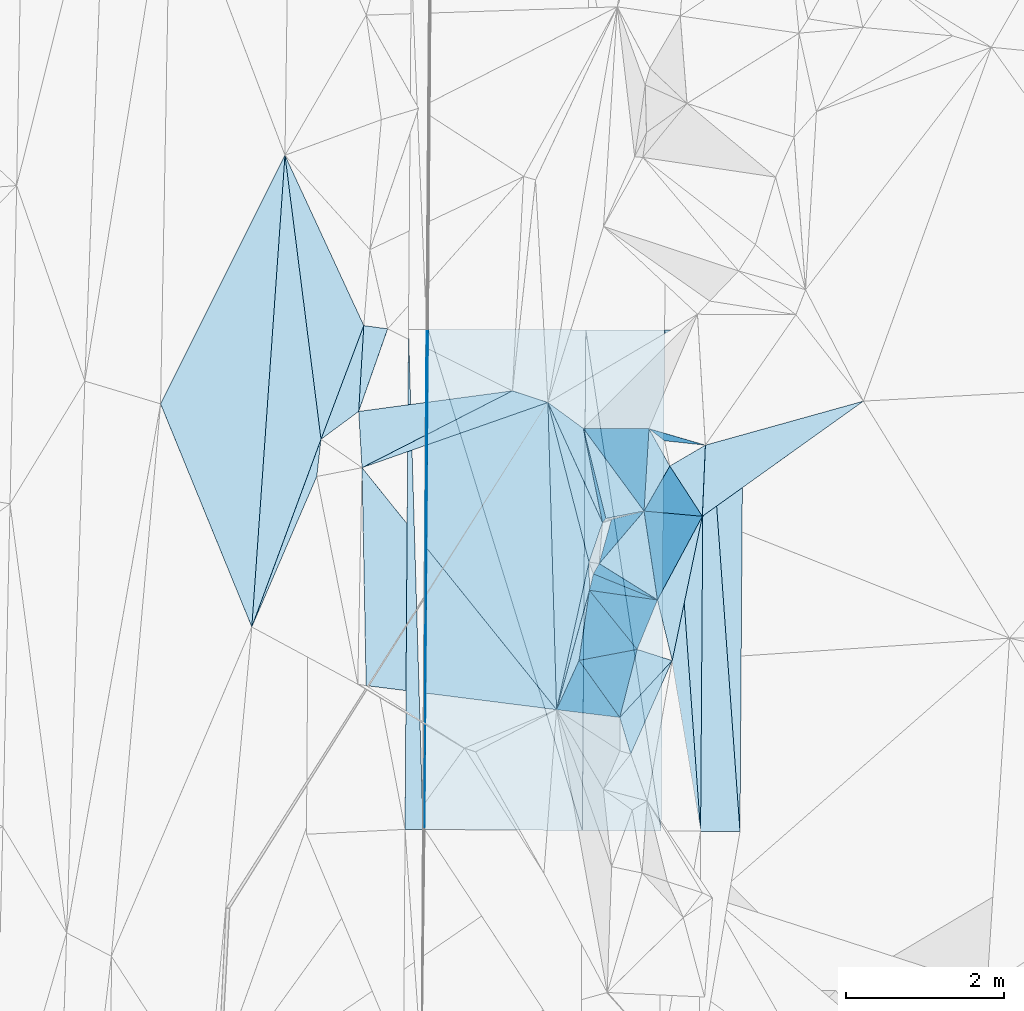
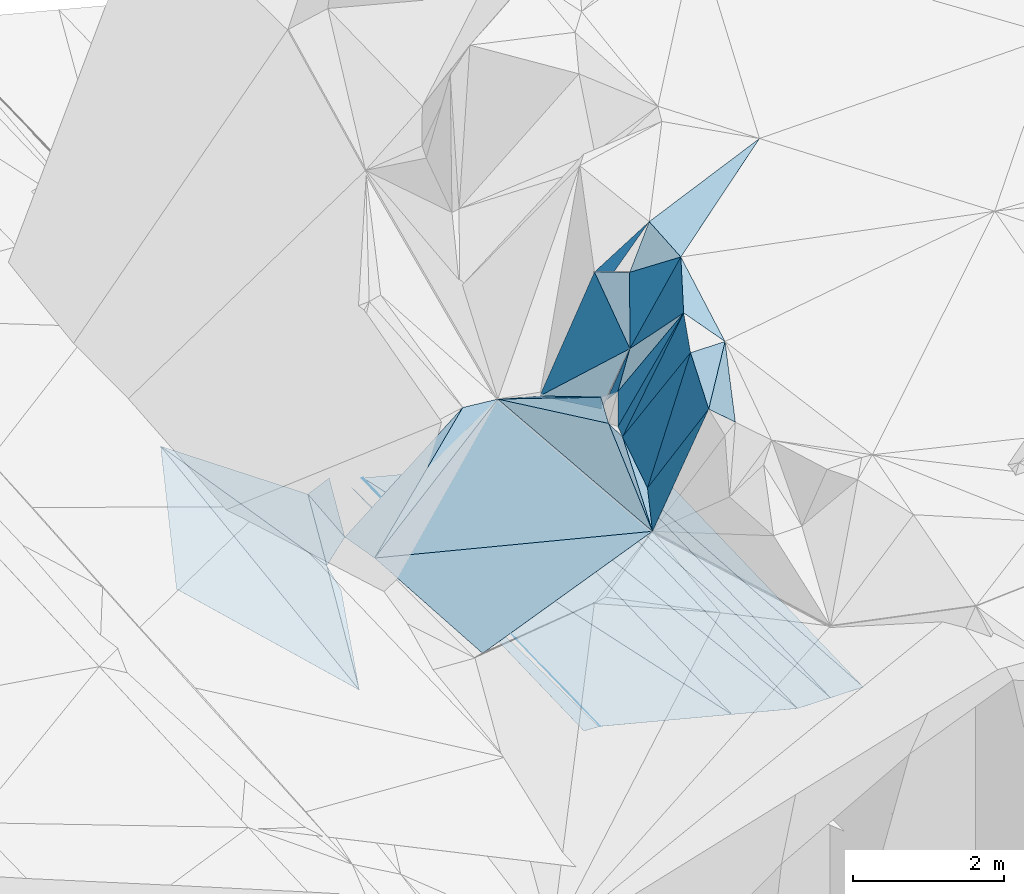
# One storey, part 151 of 275: 45 plates.
"""IFC2X3 building model written with IfcOpenShell, lengths in millimetres."""

from ifc_helpers import new_model, si_unit, frame, origin_with_axes, place, context, subcontext, project, spatial, polyline, outline, extrude, material, type_object, element, save


model = new_model("IFC2X3")

# Units and contexts
model_context = context("Model", 3, precision=1e-05, world=origin_with_axes())
body_context = subcontext(model_context, "Body", "Model", "MODEL_VIEW")
ifc_project = project(units=[si_unit("LENGTHUNIT", "METRE", prefix="MILLI"), si_unit("AREAUNIT", "SQUARE_METRE"), si_unit("VOLUMEUNIT", "CUBIC_METRE"), si_unit("MASSUNIT", "GRAM", prefix="KILO"), si_unit("TIMEUNIT", "SECOND"), si_unit("PLANEANGLEUNIT", "RADIAN"), si_unit("SOLIDANGLEUNIT", "STERADIAN"), si_unit("THERMODYNAMICTEMPERATUREUNIT", "DEGREE_CELSIUS"), si_unit("LUMINOUSINTENSITYUNIT", "LUMEN")], contexts=[model_context])

# Site, building, storey
site_placement = place(None, origin_with_axes())
site = spatial("IfcSite", under=ifc_project, at=site_placement, CompositionType="ELEMENT")
building_placement = place(site_placement, origin_with_axes())
building = spatial("IfcBuilding", under=site, at=building_placement, Name="Undefined", CompositionType="ELEMENT")
storey_placement = place(building_placement, origin_with_axes())
storey = spatial("IfcBuildingStorey", under=building, at=storey_placement, Name="Undefined", CompositionType="ELEMENT", Elevation=0.0)

# Plates
ifc_material = material()
plate_type_1 = type_object("IfcPlateType", PredefinedType="NOTDEFINED")
plate_1_placement = place(storey_placement, frame((-56001.0922795183, 121927.905972609, 43287.7527590777), z_axis=(-0.0497168788209874, 0.0234397140197796, -0.998488263209423), x_axis=(0.00374288792598746, 0.999721923798681, 0.0232823080092753)))
element("IfcPlate", 1, at=plate_1_placement, inside=storey, type_object=plate_type_1, material=ifc_material, Name="00_PR", context=body_context, shape_type="SweptSolid", body=[
    extrude(outline(polyline([(0.0, 0.0), (6347.1796875, 1.09139364212751e-09), (6347.1806640625, 20.0242137908936), (0.0, 0.0)])), frame((-8.85201319254618e-08, 2.18876761149539e-07, -0.5000001331573), z_axis=(0.0, 0.0, 1.0), x_axis=(1.0, 0.0, 0.0)), (0.0, 0.0, 1.0), 1.0),
])
plate_type_2 = type_object("IfcPlateType", PredefinedType="NOTDEFINED")
plate_2_placement = place(storey_placement, frame((-54328.6092559601, 123448.215957346, 44928.528851486), z_axis=(0.255303228601338, 0.21652061744537, -0.942305196678236), x_axis=(0.25502810990825, 0.925007291391266, 0.28164192519868)))
element("IfcPlate", 2, at=plate_2_placement, inside=storey, type_object=plate_type_2, material=ifc_material, Name="00", context=body_context, shape_type="SweptSolid", body=[
    extrude(outline(polyline([(0.0, 0.0), (1636.83020019531, -5.96628524363041e-10), (713.142395019531, 111.359382629395), (0.0, 0.0)])), frame((-8.85201319254618e-08, 2.18876761149539e-07, -0.5000001331573), z_axis=(0.0, 0.0, 1.0), x_axis=(1.0, 0.0, 0.0)), (0.0, 0.0, 1.0), 1.0),
])
plate_type_3 = type_object("IfcPlateType", PredefinedType="NOTDEFINED")
plate_3_placement = place(storey_placement, frame((-52501.1382562294, 121905.627300708, 42537.7521357024), z_axis=(0.000147264085346254, 0.0231375696408005, -0.999732279755138), x_axis=(0.00689524187971411, 0.999708501001947, 0.0231380350043184)))
element("IfcPlate", 3, at=plate_3_placement, inside=storey, type_object=plate_type_3, material=ifc_material, Name="00_PR", context=body_context, shape_type="SweptSolid", body=[
    extrude(outline(polyline([(0.0, 0.0), (6360.56591796875, -3.68527253158391e-08), (0.266177088022232, 499.999298095703), (0.0, 0.0)])), frame((-8.85201319254618e-08, 2.18876761149539e-07, -0.5000001331573), z_axis=(0.0, 0.0, 1.0), x_axis=(1.0, 0.0, 0.0)), (0.0, 0.0, 1.0), 1.0),
])
plate_4_placement = place(storey_placement, frame((-53001.1288192393, 121908.81010767, 42537.7521355578), z_axis=(0.000147275333863045, 0.0231357015361885, -0.999732322986711), x_axis=(0.00689520387458397, 0.999708544496369, 0.0231361670221856)))
element("IfcPlate", 4, at=plate_4_placement, inside=storey, type_object=plate_type_3, material=ifc_material, Name="00_PR", context=body_context, shape_type="SweptSolid", body=[
    extrude(outline(polyline([(0.0, 0.0), (6358.6591796875, -4.38012648373842e-08), (0.26565757393837, 500.000610351563), (0.0, 0.0)])), frame((-8.85201319254618e-08, 2.18876761149539e-07, -0.5000001331573), z_axis=(0.0, 0.0, 1.0), x_axis=(1.0, 0.0, 0.0)), (0.0, 0.0, 1.0), 1.0),
])
plate_type_4 = type_object("IfcPlateType", PredefinedType="NOTDEFINED")
plate_5_placement = place(storey_placement, frame((-56251.0873551612, 121929.496915818, 43300.2527590753), z_axis=(-0.0497761688804347, 0.0234391149956503, -0.998485323327192), x_axis=(0.00689365892853949, 0.99970883258603, 0.0231241760080976)))
element("IfcPlate", 5, at=plate_5_placement, inside=storey, type_object=plate_type_4, material=ifc_material, Name="00_PR", context=body_context, shape_type="SweptSolid", body=[
    extrude(outline(polyline([(0.0, 0.0), (6346.2587890625, 5.02768671140075e-09), (-0.144051283597946, 230.286834716797), (0.0, 0.0)])), frame((-8.85201319254618e-08, 2.18876761149539e-07, -0.5000001331573), z_axis=(0.0, 0.0, 1.0), x_axis=(1.0, 0.0, 0.0)), (0.0, 0.0, 1.0), 1.0),
])
plate_type_5 = type_object("IfcPlateType", PredefinedType="NOTDEFINED")
plate_6_placement = place(storey_placement, frame((-51957.2761406581, 128263.064040456, 42684.9791359133), z_axis=(0.00017098723566966, 0.0231392690260512, -0.999732236647546), x_axis=(-0.00689556590937803, -0.999708455647234, -0.0231398979732495)))
element("IfcPlate", 6, at=plate_6_placement, inside=storey, type_object=plate_type_5, material=ifc_material, Name="00_PR", context=body_context, shape_type="SweptSolid", body=[
    extrude(outline(polyline([(0.0, 0.0), (6362.47412109375, 1.97615008801222e-08), (2.17418122291565, 500.001373291016), (0.0, 0.0)])), frame((-8.85201319254618e-08, 2.18876761149539e-07, -0.5000001331573), z_axis=(0.0, 0.0, 1.0), x_axis=(1.0, 0.0, 0.0)), (0.0, 0.0, 1.0), 1.0),
])
plate_7_placement = place(storey_placement, frame((-52457.2806044433, 128264.339338575, 42684.9231357941), z_axis=(0.000171043884283166, 0.0231374056254346, -0.999732279765395), x_axis=(-0.00689524188068983, -0.999708501001948, -0.0231380350039911)))
element("IfcPlate", 7, at=plate_7_placement, inside=storey, type_object=plate_type_5, material=ifc_material, Name="00_PR", context=body_context, shape_type="SweptSolid", body=[
    extrude(outline(polyline([(0.0, 0.0), (6360.56591796875, -3.68527253158391e-08), (2.172696352005, 500.000854492188), (0.0, 0.0)])), frame((-8.85201319254618e-08, 2.18876761149539e-07, -0.5000001331573), z_axis=(0.0, 0.0, 1.0), x_axis=(1.0, 0.0, 0.0)), (0.0, 0.0, 1.0), 1.0),
])
plate_type_6 = type_object("IfcPlateType", PredefinedType="NOTDEFINED")
plate_8_placement = place(storey_placement, frame((-52957.4057922976, 128265.61644964, 42684.8820515383), z_axis=(-0.242302793099637, 0.024117544904854, -0.969900871472893), x_axis=(-0.00689520387730406, -0.999708544496402, -0.0231361670199542)))
element("IfcPlate", 8, at=plate_8_placement, inside=storey, type_object=plate_type_6, material=ifc_material, Name="00_PR", context=body_context, shape_type="SweptSolid", body=[
    extrude(outline(polyline([(0.0, 0.0), (6358.6591796875, -4.38012648373842e-08), (-1.43695330619812, 1030.76049804688), (0.0, 0.0)])), frame((-8.85201319254618e-08, 2.18876761149539e-07, -0.5000001331573), z_axis=(0.0, 0.0, 1.0), x_axis=(1.0, 0.0, 0.0)), (0.0, 0.0, 1.0), 1.0),
])
plate_9_placement = place(storey_placement, frame((-54001.2298594987, 121915.175695106, 42787.7670540484), z_axis=(-0.242325245624138, 0.0241138246358994, -0.969895354558743), x_axis=(0.00689469788792795, 0.999708634394564, 0.0231324330322171)))
element("IfcPlate", 9, at=plate_9_placement, inside=storey, type_object=plate_type_6, material=ifc_material, Name="00_PR", context=body_context, shape_type="SweptSolid", body=[
    extrude(outline(polyline([(0.0, 0.0), (6354.84375, 3.70855559594929e-08), (-5.25179862976074, 1030.76306152344), (0.0, 0.0)])), frame((-8.85201319254618e-08, 2.18876761149539e-07, -0.5000001331573), z_axis=(0.0, 0.0, 1.0), x_axis=(1.0, 0.0, 0.0)), (0.0, 0.0, 1.0), 1.0),
])
plate_type_7 = type_object("IfcPlateType", PredefinedType="NOTDEFINED")
plate_10_placement = place(storey_placement, frame((-55957.4324484603, 128273.270476872, 43434.5470512358), z_axis=(-0.242303436498094, 0.0241138005015226, -0.96990080383851), x_axis=(0.970165469879808, -0.00247512188093162, -0.242431092940995)))
element("IfcPlate", 10, at=plate_10_placement, inside=storey, type_object=plate_type_7, material=ifc_material, Name="00_PR", context=body_context, shape_type="SweptSolid", body=[
    extrude(outline(polyline([(0.0, 0.0), (2061.52197265625, 4.61295712739229e-09), (2070.376953125, 6354.837890625), (0.0, 0.0)])), frame((-8.85201319254618e-08, 2.18876761149539e-07, -0.5000001331573), z_axis=(0.0, 0.0, 1.0), x_axis=(1.0, 0.0, 0.0)), (0.0, 0.0, 1.0), 1.0),
])
plate_type_8 = type_object("IfcPlateType", PredefinedType="NOTDEFINED")
plate_11_placement = place(storey_placement, frame((-55957.4324484603, 128273.270476872, 43434.5470512358), z_axis=(-0.242325431720713, 0.0241064926841434, -0.969895490324519), x_axis=(0.292687249134254, -0.951298844031144, -0.0967712950168195)))
element("IfcPlate", 11, at=plate_11_placement, inside=storey, type_object=plate_type_8, material=ifc_material, Name="00_PR", context=body_context, shape_type="SweptSolid", body=[
    extrude(outline(polyline([(0.0, 0.0), (6683.59375, 3.28655005432665e-08), (6037.73486328125, 1957.77001953125), (0.0, 0.0)])), frame((-8.85201319254618e-08, 2.18876761149539e-07, -0.5000001331573), z_axis=(0.0, 0.0, 1.0), x_axis=(1.0, 0.0, 0.0)), (0.0, 0.0, 1.0), 1.0),
])
plate_type_9 = type_object("IfcPlateType", PredefinedType="NOTDEFINED")
plate_12_placement = place(storey_placement, frame((-53387.166340567, 122886.851759459, 46699.5569787593), z_axis=(0.453175417801132, 0.0979237538987491, -0.886026511523863), x_axis=(-0.287532499343744, 0.956879604337603, -0.0413096190233257)))
element("IfcPlate", 12, at=plate_12_placement, inside=storey, type_object=plate_type_9, material=ifc_material, Name="00", context=body_context, shape_type="SweptSolid", body=[
    extrude(outline(polyline([(0.0, 0.0), (484.148742675781, -1.54250301420689e-09), (964.99267578125, 952.517211914063), (0.0, 0.0)])), frame((-8.85201319254618e-08, 2.18876761149539e-07, -0.5000001331573), z_axis=(0.0, 0.0, 1.0), x_axis=(1.0, 0.0, 0.0)), (0.0, 0.0, 1.0), 1.0),
])
plate_type_10 = type_object("IfcPlateType", PredefinedType="NOTDEFINED")
plate_13_placement = place(storey_placement, frame((-57316.9926377495, 126878.743560531, 43339.5068959017), z_axis=(0.165709531410516, -0.000848531309702812, -0.986174239774252), x_axis=(0.351640904343267, 0.934318861990843, 0.058283261068556)))
element("IfcPlate", 13, at=plate_13_placement, inside=storey, type_object=plate_type_10, material=ifc_material, Name="00", context=body_context, shape_type="SweptSolid", body=[
    extrude(outline(polyline([(0.0, 0.0), (1544.1826171875, -2.35741026699543e-09), (502.919799804688, 326.759368896484), (0.0, 0.0)])), frame((-8.85201319254618e-08, 2.18876761149539e-07, -0.5000001331573), z_axis=(0.0, 0.0, 1.0), x_axis=(1.0, 0.0, 0.0)), (0.0, 0.0, 1.0), 1.0),
])
plate_type_11 = type_object("IfcPlateType", PredefinedType="NOTDEFINED")
plate_14_placement = place(storey_placement, frame((-57774.4066346961, 130482.623841324, 43243.5081506116), z_axis=(-0.175732205588709, 0.0386520921781757, -0.983678914935752), x_axis=(-0.0701137544389572, -0.99718276376502, -0.0266570269990824)))
element("IfcPlate", 14, at=plate_14_placement, inside=storey, type_object=plate_type_11, material=ifc_material, Name="00", context=body_context, shape_type="SweptSolid", body=[
    extrude(outline(polyline([(0.0, 0.0), (6002.169921875, -5.25324139744043e-09), (3252.09106445313, 1375.0771484375), (0.0, 0.0)])), frame((-8.85201319254618e-08, 2.18876761149539e-07, -0.5000001331573), z_axis=(0.0, 0.0, 1.0), x_axis=(1.0, 0.0, 0.0)), (0.0, 0.0, 1.0), 1.0),
])
plate_type_12 = type_object("IfcPlateType", PredefinedType="NOTDEFINED")
plate_15_placement = place(storey_placement, frame((-53048.5054921934, 124840.718056682, 47159.5014563602), z_axis=(-0.0273068669384299, 0.0710520201318311, -0.997098764141844), x_axis=(0.472476560067046, 0.879937191340254, 0.0497638371052258)))
element("IfcPlate", 15, at=plate_15_placement, inside=storey, type_object=plate_type_12, material=ifc_material, Name="00", context=body_context, shape_type="SweptSolid", body=[
    extrude(outline(polyline([(0.0, 0.0), (1205.69482421875, -2.6338966563344e-09), (-592.023803710938, 530.196044921875), (0.0, 0.0)])), frame((-8.85201319254618e-08, 2.18876761149539e-07, -0.5000001331573), z_axis=(0.0, 0.0, 1.0), x_axis=(1.0, 0.0, 0.0)), (0.0, 0.0, 1.0), 1.0),
])
plate_type_13 = type_object("IfcPlateType", PredefinedType="NOTDEFINED")
plate_16_placement = place(storey_placement, frame((-53048.1583882639, 124840.43578799, 47159.7208484749), z_axis=(0.666902251379512, -0.493484165114308, -0.558314217879478), x_axis=(-0.474975247137563, 0.295790272119445, -0.828798304490372)))
element("IfcPlate", 16, at=plate_16_placement, inside=storey, type_object=plate_type_13, material=ifc_material, Name="00", context=body_context, shape_type="SweptSolid", body=[
    extrude(outline(polyline([(0.0, 0.0), (1556.47033691406, 2.8521753847599e-09), (1408.95715332031, 868.815185546875), (0.0, 0.0)])), frame((-8.85201319254618e-08, 2.18876761149539e-07, -0.5000001331573), z_axis=(0.0, 0.0, 1.0), x_axis=(1.0, 0.0, 0.0)), (0.0, 0.0, 1.0), 1.0),
])
plate_type_14 = type_object("IfcPlateType", PredefinedType="NOTDEFINED")
plate_17_placement = place(storey_placement, frame((-53701.9576377282, 125874.589852396, 45209.7279313081), z_axis=(0.83848689239507, 0.0290143231678006, -0.544148785106402), x_axis=(-0.231311996936513, 0.923101118518461, -0.30721179186875)))
element("IfcPlate", 17, at=plate_17_placement, inside=storey, type_object=plate_type_14, material=ifc_material, Name="00", context=body_context, shape_type="SweptSolid", body=[
    extrude(outline(polyline([(0.0, 0.0), (1236.931640625, -8.76025296747684e-09), (-255.955932617188, 859.934020996094), (0.0, 0.0)])), frame((-8.85201319254618e-08, 2.18876761149539e-07, -0.5000001331573), z_axis=(0.0, 0.0, 1.0), x_axis=(1.0, 0.0, 0.0)), (0.0, 0.0, 1.0), 1.0),
])
plate_type_15 = type_object("IfcPlateType", PredefinedType="NOTDEFINED")
plate_18_placement = place(storey_placement, frame((-53745.5844810632, 125822.722479415, 45449.8846314924), z_axis=(-0.92295621117036, -0.308069725548733, -0.230748513456494), x_axis=(-0.178060994984504, 0.873226037765476, -0.453619409895054)))
element("IfcPlate", 18, at=plate_18_placement, inside=storey, type_object=plate_type_15, material=ifc_material, Name="00", context=body_context, shape_type="SweptSolid", body=[
    extrude(outline(polyline([(0.0, 0.0), (1366.78454589844, -4.26371116191149e-09), (146.402008056641, 201.659255981445), (0.0, 0.0)])), frame((-8.85201319254618e-08, 2.18876761149539e-07, -0.5000001331573), z_axis=(0.0, 0.0, 1.0), x_axis=(1.0, 0.0, 0.0)), (0.0, 0.0, 1.0), 1.0),
])
plate_type_16 = type_object("IfcPlateType", PredefinedType="NOTDEFINED")
plate_19_placement = place(storey_placement, frame((-53630.963315193, 125861.967806464, 45339.8067087224), z_axis=(0.726788877395248, -0.567734417077406, -0.386594825832335), x_axis=(0.548361173782464, 0.140669519035923, 0.82432524497441)))
element("IfcPlate", 19, at=plate_19_placement, inside=storey, type_object=plate_type_16, material=ifc_material, Name="00", context=body_context, shape_type="SweptSolid", body=[
    extrude(outline(polyline([(0.0, 0.0), (752.130310058594, 2.91038304567337e-11), (272.160278320313, 739.072937011719), (0.0, 0.0)])), frame((-8.85201319254618e-08, 2.18876761149539e-07, -0.5000001331573), z_axis=(0.0, 0.0, 1.0), x_axis=(1.0, 0.0, 0.0)), (0.0, 0.0, 1.0), 1.0),
])
plate_type_17 = type_object("IfcPlateType", PredefinedType="NOTDEFINED")
plate_20_placement = place(storey_placement, frame((-53218.4959030338, 125967.856735659, 45959.7595399758), z_axis=(0.783496092502468, -0.393494563051655, -0.480932325678106), x_axis=(0.505928935848593, -0.0454173789493915, 0.861378647030723)))
element("IfcPlate", 20, at=plate_20_placement, inside=storey, type_object=plate_type_17, material=ifc_material, Name="00", context=body_context, shape_type="SweptSolid", body=[
    extrude(outline(polyline([(0.0, 0.0), (1462.77136230469, 3.31783667206764e-09), (1171.06481933594, 1169.87487792969), (0.0, 0.0)])), frame((-8.85201319254618e-08, 2.18876761149539e-07, -0.5000001331573), z_axis=(0.0, 0.0, 1.0), x_axis=(1.0, 0.0, 0.0)), (0.0, 0.0, 1.0), 1.0),
])
plate_type_18 = type_object("IfcPlateType", PredefinedType="NOTDEFINED")
plate_21_placement = place(storey_placement, frame((-53988.0521886792, 127016.481060007, 44829.7850821287), z_axis=(0.883664528276025, 0.185384852383932, -0.42984818014422), x_axis=(0.437756702967693, -0.00192715896733418, 0.899091405289345)))
element("IfcPlate", 21, at=plate_21_placement, inside=storey, type_object=plate_type_18, material=ifc_material, Name="00", context=body_context, shape_type="SweptSolid", body=[
    extrude(outline(polyline([(0.0, 0.0), (1901.92004394531, -3.05590219795704e-09), (1354.89392089844, 1064.17211914063), (0.0, 0.0)])), frame((-8.85201319254618e-08, 2.18876761149539e-07, -0.5000001331573), z_axis=(0.0, 0.0, 1.0), x_axis=(1.0, 0.0, 0.0)), (0.0, 0.0, 1.0), 1.0),
])
plate_type_19 = type_object("IfcPlateType", PredefinedType="NOTDEFINED")
plate_22_placement = place(storey_placement, frame((-50435.0375889187, 127362.755499579, 47529.5054190878), z_axis=(0.14665922373712, 0.00473216731948835, -0.989175757226837), x_axis=(-0.80735878734774, -0.577212648337659, -0.122463656206287)))
element("IfcPlate", 22, at=plate_22_placement, inside=storey, type_object=plate_type_19, material=ifc_material, Name="00", context=body_context, shape_type="SweptSolid", body=[
    extrude(outline(polyline([(0.0, 0.0), (2531.36328125, 6.66477717459202e-09), (1978.22253417969, 714.3076171875), (0.0, 0.0)])), frame((-8.85201319254618e-08, 2.18876761149539e-07, -0.5000001331573), z_axis=(0.0, 0.0, 1.0), x_axis=(1.0, 0.0, 0.0)), (0.0, 0.0, 1.0), 1.0),
])
plate_type_20 = type_object("IfcPlateType", PredefinedType="NOTDEFINED")
plate_23_placement = place(storey_placement, frame((-53526.1642327906, 123349.948262627, 46679.7927043984), z_axis=(0.87411178371926, -0.253053048585127, -0.414599498510197), x_axis=(-0.415942008804216, 0.050834302981378, -0.907969227976538)))
element("IfcPlate", 23, at=plate_23_placement, inside=storey, type_object=plate_type_20, material=ifc_material, Name="00", context=body_context, shape_type="SweptSolid", body=[
    extrude(outline(polyline([(0.0, 0.0), (1928.4794921875, 4.72937244921923e-09), (1640.73828125, 661.950134277344), (0.0, 0.0)])), frame((-8.85201319254618e-08, 2.18876761149539e-07, -0.5000001331573), z_axis=(0.0, 0.0, 1.0), x_axis=(1.0, 0.0, 0.0)), (0.0, 0.0, 1.0), 1.0),
])
plate_24_placement = place(storey_placement, frame((-53048.0585179192, 124840.563785941, 47159.7806215943), z_axis=(0.866664785313313, -0.237438594440996, -0.438765385790302), x_axis=(-0.368774800811256, -0.897225453992639, -0.242881928093303)))
element("IfcPlate", 24, at=plate_24_placement, inside=storey, type_object=plate_type_20, material=ifc_material, Name="00", context=body_context, shape_type="SweptSolid", body=[
    extrude(outline(polyline([(0.0, 0.0), (699.928588867188, -4.26371116191149e-09), (639.065185546875, 1866.46606445313), (0.0, 0.0)])), frame((-8.85201319254618e-08, 2.18876761149539e-07, -0.5000001331573), z_axis=(0.0, 0.0, 1.0), x_axis=(1.0, 0.0, 0.0)), (0.0, 0.0, 1.0), 1.0),
])
plate_type_21 = type_object("IfcPlateType", PredefinedType="NOTDEFINED")
plate_25_placement = place(storey_placement, frame((-53155.6277733916, 127013.08545149, 46539.8109418486), z_axis=(0.575959478912452, 0.724769455877092, -0.378126849719139), x_axis=(0.704436829903549, -0.205336718001203, 0.679415620158922)))
element("IfcPlate", 25, at=plate_25_placement, inside=storey, type_object=plate_type_21, material=ifc_material, Name="00", context=body_context, shape_type="SweptSolid", body=[
    extrude(outline(polyline([(0.0, 0.0), (1015.57867431641, -2.3283064365387e-09), (178.125045776367, 176.554428100586), (0.0, 0.0)])), frame((-8.85201319254618e-08, 2.18876761149539e-07, -0.5000001331573), z_axis=(0.0, 0.0, 1.0), x_axis=(1.0, 0.0, 0.0)), (0.0, 0.0, 1.0), 1.0),
])
plate_type_22 = type_object("IfcPlateType", PredefinedType="NOTDEFINED")
plate_26_placement = place(storey_placement, frame((-52891.4133470831, 126539.13969783, 46729.7541021883), z_axis=(0.853011765586547, 0.174633730828547, -0.491806860289509), x_axis=(0.456930473973394, -0.705219464073106, 0.54210704611441)))
element("IfcPlate", 26, at=plate_26_placement, inside=storey, type_object=plate_type_22, material=ifc_material, Name="00", context=body_context, shape_type="SweptSolid", body=[
    extrude(outline(polyline([(0.0, 0.0), (903.880493164063, 6.67932908982039e-09), (-164.18098449707, 999.47216796875), (0.0, 0.0)])), frame((-8.85201319254618e-08, 2.18876761149539e-07, -0.5000001331573), z_axis=(0.0, 0.0, 1.0), x_axis=(1.0, 0.0, 0.0)), (0.0, 0.0, 1.0), 1.0),
])
plate_type_23 = type_object("IfcPlateType", PredefinedType="NOTDEFINED")
plate_27_placement = place(storey_placement, frame((-53155.5083653088, 127012.844623645, 46539.7368321604), z_axis=(0.814772618262494, 0.243113759277953, -0.526347110355344), x_axis=(0.45955789720277, -0.824305076408199, 0.330647365218962)))
element("IfcPlate", 27, at=plate_27_placement, inside=storey, type_object=plate_type_23, material=ifc_material, Name="00", context=body_context, shape_type="SweptSolid", body=[
    extrude(outline(polyline([(0.0, 0.0), (574.630310058594, 1.35332811623812e-09), (640.411743164063, 1010.72882080078), (0.0, 0.0)])), frame((-8.85201319254618e-08, 2.18876761149539e-07, -0.5000001331573), z_axis=(0.0, 0.0, 1.0), x_axis=(1.0, 0.0, 0.0)), (0.0, 0.0, 1.0), 1.0),
])
plate_type_24 = type_object("IfcPlateType", PredefinedType="NOTDEFINED")
plate_28_placement = place(storey_placement, frame((-53745.2106607704, 125822.635631751, 45449.5707143314), z_axis=(-0.175326574435101, -0.481763713361679, -0.858582737297239), x_axis=(-0.381005530931139, 0.837340172943295, -0.392041095008131)))
element("IfcPlate", 28, at=plate_28_placement, inside=storey, type_object=plate_type_24, material=ifc_material, Name="00", context=body_context, shape_type="SweptSolid", body=[
    extrude(outline(polyline([(0.0, 0.0), (1818.68688964844, -6.1918399296701e-09), (1335.16662597656, 292.284332275391), (0.0, 0.0)])), frame((-8.85201319254618e-08, 2.18876761149539e-07, -0.5000001331573), z_axis=(0.0, 0.0, 1.0), x_axis=(1.0, 0.0, 0.0)), (0.0, 0.0, 1.0), 1.0),
])
plate_type_25 = type_object("IfcPlateType", PredefinedType="NOTDEFINED")
plate_29_placement = place(storey_placement, frame((-53916.3924241921, 125320.563001325, 45389.5999122917), z_axis=(0.590301129778945, -0.106047703495608, -0.800186516235439), x_axis=(-0.237985874963445, 0.92439998690897, -0.298072788963668)))
element("IfcPlate", 29, at=plate_29_placement, inside=storey, type_object=plate_type_25, material=ifc_material, Name="00", context=body_context, shape_type="SweptSolid", body=[
    extrude(outline(polyline([(0.0, 0.0), (2190.73999023438, -9.61154000833631e-09), (405.575286865234, 347.575469970703), (0.0, 0.0)])), frame((-8.85201319254618e-08, 2.18876761149539e-07, -0.5000001331573), z_axis=(0.0, 0.0, 1.0), x_axis=(1.0, 0.0, 0.0)), (0.0, 0.0, 1.0), 1.0),
])
plate_type_26 = type_object("IfcPlateType", PredefinedType="NOTDEFINED")
plate_30_placement = place(storey_placement, frame((-53306.4544224691, 124212.814598185, 46989.5410592259), z_axis=(0.306869851796905, 0.251604150023161, -0.917892284393582), x_axis=(0.927436023116981, -0.295657496021994, 0.229017615197964)))
element("IfcPlate", 30, at=plate_30_placement, inside=storey, type_object=plate_type_26, material=ifc_material, Name="00", context=body_context, shape_type="SweptSolid", body=[
    extrude(outline(polyline([(0.0, 0.0), (480.312408447266, 1.51339918375015e-09), (-19.9869918823242, 942.443908691406), (0.0, 0.0)])), frame((-8.85201319254618e-08, 2.18876761149539e-07, -0.5000001331573), z_axis=(0.0, 0.0, 1.0), x_axis=(1.0, 0.0, 0.0)), (0.0, 0.0, 1.0), 1.0),
])
plate_type_27 = type_object("IfcPlateType", PredefinedType="NOTDEFINED")
plate_31_placement = place(storey_placement, frame((-53860.7349103326, 125170.495838942, 45409.8615483758), z_axis=(0.807520390564956, 0.520797200711279, -0.276913514572903), x_axis=(0.151624741885232, 0.270412111090817, 0.950729839556771)))
element("IfcPlate", 31, at=plate_31_placement, inside=storey, type_object=plate_type_27, material=ifc_material, Name="00", context=body_context, shape_type="SweptSolid", body=[
    extrude(outline(polyline([(0.0, 0.0), (483.838806152344, 2.3283064365387e-10), (1697.87951660156, 974.015014648438), (0.0, 0.0)])), frame((-8.85201319254618e-08, 2.18876761149539e-07, -0.5000001331573), z_axis=(0.0, 0.0, 1.0), x_axis=(1.0, 0.0, 0.0)), (0.0, 0.0, 1.0), 1.0),
])
plate_type_28 = type_object("IfcPlateType", PredefinedType="NOTDEFINED")
plate_32_placement = place(storey_placement, frame((-53526.1383097981, 123350.02187902, 46679.8187348365), z_axis=(0.925936792068439, -0.105855484776717, -0.362540581779052), x_axis=(-0.291881856763436, 0.408609095920657, -0.864779502776998)))
element("IfcPlate", 32, at=plate_32_placement, inside=storey, type_object=plate_type_28, material=ifc_material, Name="00", context=body_context, shape_type="SweptSolid", body=[
    extrude(outline(polyline([(0.0, 0.0), (1769.23718261719, -7.27595761418343e-11), (20.1781883239746, 942.439819335938), (0.0, 0.0)])), frame((-8.85201319254618e-08, 2.18876761149539e-07, -0.5000001331573), z_axis=(0.0, 0.0, 1.0), x_axis=(1.0, 0.0, 0.0)), (0.0, 0.0, 1.0), 1.0),
])
plate_type_29 = type_object("IfcPlateType", PredefinedType="NOTDEFINED")
plate_33_placement = place(storey_placement, frame((-54328.3540221147, 123448.102600207, 44928.6784872993), z_axis=(0.765770976404574, -0.0101988482501334, -0.643032499327022), x_axis=(-0.028001813162768, 0.998397241464166, -0.0491817719926976)))
element("IfcPlate", 33, at=plate_33_placement, inside=storey, type_object=plate_type_29, material=ifc_material, Name="00", context=body_context, shape_type="SweptSolid", body=[
    extrude(outline(polyline([(0.0, 0.0), (3903.88525390625, -1.62108335644007e-08), (1835.29614257813, 721.304931640625), (0.0, 0.0)])), frame((-8.85201319254618e-08, 2.18876761149539e-07, -0.5000001331573), z_axis=(0.0, 0.0, 1.0), x_axis=(1.0, 0.0, 0.0)), (0.0, 0.0, 1.0), 1.0),
])
plate_type_30 = type_object("IfcPlateType", PredefinedType="NOTDEFINED")
plate_34_placement = place(storey_placement, frame((-54042.5451426664, 124072.98215932, 45149.815600608), z_axis=(0.928727867901006, -0.0380227146415161, -0.36880729460701), x_axis=(0.141566706857199, 0.95572769630195, 0.257960148144971)))
element("IfcPlate", 34, at=plate_34_placement, inside=storey, type_object=plate_type_30, material=ifc_material, Name="00", context=body_context, shape_type="SweptSolid", body=[
    extrude(outline(polyline([(0.0, 0.0), (930.376281738281, -5.15137799084187e-09), (712.399963378906, 1854.69299316406), (0.0, 0.0)])), frame((-8.85201319254618e-08, 2.18876761149539e-07, -0.5000001331573), z_axis=(0.0, 0.0, 1.0), x_axis=(1.0, 0.0, 0.0)), (0.0, 0.0, 1.0), 1.0),
])
plate_type_31 = type_object("IfcPlateType", PredefinedType="NOTDEFINED")
plate_35_placement = place(storey_placement, frame((-53910.9376066596, 124962.192973922, 45389.6547234714), z_axis=(0.723192152090869, 0.0108720079878383, -0.690561301114166), x_axis=(-0.25502810991459, -0.925007291389476, -0.281641925198818)))
element("IfcPlate", 35, at=plate_35_placement, inside=storey, type_object=plate_type_31, material=ifc_material, Name="00", context=body_context, shape_type="SweptSolid", body=[
    extrude(outline(polyline([(0.0, 0.0), (1636.83020019531, -5.96628524363041e-10), (-330.174743652344, 139.587356567383), (0.0, 0.0)])), frame((-8.85201319254618e-08, 2.18876761149539e-07, -0.5000001331573), z_axis=(0.0, 0.0, 1.0), x_axis=(1.0, 0.0, 0.0)), (0.0, 0.0, 1.0), 1.0),
])
plate_type_32 = type_object("IfcPlateType", PredefinedType="NOTDEFINED")
plate_36_placement = place(storey_placement, frame((-53048.051273489, 124840.597489257, 47159.7794037614), z_axis=(0.881153006685872, -0.17003335090098, -0.441200678138454), x_axis=(-0.437342659997671, 0.0615888749973095, -0.897183486374291)))
element("IfcPlate", 36, at=plate_36_placement, inside=storey, type_object=plate_type_32, material=ifc_material, Name="00", context=body_context, shape_type="SweptSolid", body=[
    extrude(outline(polyline([(0.0, 0.0), (1972.84057617188, -4.78758011013269e-09), (1945.77307128906, 213.230728149414), (0.0, 0.0)])), frame((-8.85201319254618e-08, 2.18876761149539e-07, -0.5000001331573), z_axis=(0.0, 0.0, 1.0), x_axis=(1.0, 0.0, 0.0)), (0.0, 0.0, 1.0), 1.0),
])
plate_type_33 = type_object("IfcPlateType", PredefinedType="NOTDEFINED")
plate_37_placement = place(storey_placement, frame((-56838.9134411307, 127232.150895818, 43419.569758959), z_axis=(0.508971659720762, -0.0225129056137359, -0.860488825425362), x_axis=(0.0596431178646058, 0.998177707339261, 0.00916313605293799)))
element("IfcPlate", 37, at=plate_37_placement, inside=storey, type_object=plate_type_33, material=ifc_material, Name="00", context=body_context, shape_type="SweptSolid", body=[
    extrude(outline(polyline([(0.0, 0.0), (1091.32946777344, 3.96539689972997e-09), (1069.8876953125, 353.751678466797), (0.0, 0.0)])), frame((-8.85201319254618e-08, 2.18876761149539e-07, -0.5000001331573), z_axis=(0.0, 0.0, 1.0), x_axis=(1.0, 0.0, 0.0)), (0.0, 0.0, 1.0), 1.0),
])
plate_type_34 = type_object("IfcPlateType", PredefinedType="NOTDEFINED")
plate_38_placement = place(storey_placement, frame((-54888.0325964428, 127493.570174779, 44669.5797157603), z_axis=(0.277643594309846, 0.46513058007507, -0.840575741987442), x_axis=(0.940851709210172, -0.308521206919857, 0.140045443185462)))
element("IfcPlate", 38, at=plate_38_placement, inside=storey, type_object=plate_type_34, material=ifc_material, Name="00", context=body_context, shape_type="SweptSolid", body=[
    extrude(outline(polyline([(0.0, 0.0), (478.416137695313, 4.65661287307739e-10), (-1658.86962890625, 1791.94067382813), (0.0, 0.0)])), frame((-8.85201319254618e-08, 2.18876761149539e-07, -0.5000001331573), z_axis=(0.0, 0.0, 1.0), x_axis=(1.0, 0.0, 0.0)), (0.0, 0.0, 1.0), 1.0),
])
plate_type_35 = type_object("IfcPlateType", PredefinedType="NOTDEFINED")
plate_39_placement = place(storey_placement, frame((-52478.4551975664, 125901.606059655, 47219.6686504278), z_axis=(0.748497792659602, -0.024440201771675, -0.662686751731966), x_axis=(-0.456930474410585, 0.70521946378646, -0.542107046118804)))
element("IfcPlate", 39, at=plate_39_placement, inside=storey, type_object=plate_type_35, material=ifc_material, Name="00", context=body_context, shape_type="SweptSolid", body=[
    extrude(outline(polyline([(0.0, 0.0), (903.880493164063, 6.67932908982039e-09), (613.57666015625, 663.116638183594), (0.0, 0.0)])), frame((-8.85201319254618e-08, 2.18876761149539e-07, -0.5000001331573), z_axis=(0.0, 0.0, 1.0), x_axis=(1.0, 0.0, 0.0)), (0.0, 0.0, 1.0), 1.0),
])
plate_type_36 = type_object("IfcPlateType", PredefinedType="NOTDEFINED")
plate_40_placement = place(storey_placement, frame((-57316.9883989484, 126878.741919303, 43339.5076310587), z_axis=(0.174186357328348, -0.00413058619831836, -0.984704042430181), x_axis=(-0.125822994595963, 0.991700919940362, -0.0264170289840411)))
element("IfcPlate", 40, at=plate_40_placement, inside=storey, type_object=plate_type_36, material=ifc_material, Name="00", context=body_context, shape_type="SweptSolid", body=[
    extrude(outline(polyline([(0.0, 0.0), (3634.01953125, 1.56651367433369e-08), (1360.08630371094, 731.208190917969), (0.0, 0.0)])), frame((-8.85201319254618e-08, 2.18876761149539e-07, -0.5000001331573), z_axis=(0.0, 0.0, 1.0), x_axis=(1.0, 0.0, 0.0)), (0.0, 0.0, 1.0), 1.0),
])
plate_type_37 = type_object("IfcPlateType", PredefinedType="NOTDEFINED")
plate_41_placement = place(storey_placement, frame((-58195.0227888832, 124497.348069711, 43083.5173701266), z_axis=(0.261250517109297, 0.00743418211255484, -0.965242404915181), x_axis=(0.070113754454362, 0.997182763763258, 0.026657027024475)))
element("IfcPlate", 41, at=plate_41_placement, inside=storey, type_object=plate_type_37, material=ifc_material, Name="00", context=body_context, shape_type="SweptSolid", body=[
    extrude(outline(polyline([(0.0, 0.0), (6002.169921875, -5.25324139744043e-09), (2443.08032226563, 734.152648925781), (0.0, 0.0)])), frame((-8.85201319254618e-08, 2.18876761149539e-07, -0.5000001331573), z_axis=(0.0, 0.0, 1.0), x_axis=(1.0, 0.0, 0.0)), (0.0, 0.0, 1.0), 1.0),
])
plate_type_38 = type_object("IfcPlateType", PredefinedType="NOTDEFINED")
plate_42_placement = place(storey_placement, frame((-56796.6374514439, 126518.258735898, 43499.5816602393), z_axis=(0.544275836411662, -0.0615396147067086, -0.836646095861407), x_axis=(-0.0587262445815509, 0.992064132877907, -0.111175466963512)))
element("IfcPlate", 42, at=plate_42_placement, inside=storey, type_object=plate_type_38, material=ifc_material, Name="00", context=body_context, shape_type="SweptSolid", body=[
    extrude(outline(polyline([(0.0, 0.0), (719.583190917969, 4.1691237129271e-09), (725.141967773438, 2331.75244140625), (0.0, 0.0)])), frame((-8.85201319254618e-08, 2.18876761149539e-07, -0.5000001331573), z_axis=(0.0, 0.0, 1.0), x_axis=(1.0, 0.0, 0.0)), (0.0, 0.0, 1.0), 1.0),
])
plate_type_39 = type_object("IfcPlateType", PredefinedType="NOTDEFINED")
plate_43_placement = place(storey_placement, frame((-54437.8166165297, 127345.72106682, 44736.5595712754), z_axis=(0.472482322761982, -0.0301384616212278, -0.880824686193881), x_axis=(0.0280018136084933, -0.998397241451799, 0.0491817719899693)))
element("IfcPlate", 43, at=plate_43_placement, inside=storey, type_object=plate_type_39, material=ifc_material, Name="00", context=body_context, shape_type="SweptSolid", body=[
    extrude(outline(polyline([(0.0, 0.0), (3903.88525390625, -1.62108335644007e-08), (699.230285644531, 2700.02197265625), (0.0, 0.0)])), frame((-8.85201319254618e-08, 2.18876761149539e-07, -0.5000001331573), z_axis=(0.0, 0.0, 1.0), x_axis=(1.0, 0.0, 0.0)), (0.0, 0.0, 1.0), 1.0),
])
plate_type_40 = type_object("IfcPlateType", PredefinedType="NOTDEFINED")
plate_44_placement = place(storey_placement, frame((-58195.3049432705, 124497.450164687, 43083.5354219414), z_axis=(-0.303140269102879, 0.211657633801282, -0.929143166203076), x_axis=(0.344208749451204, 0.933514693301667, 0.100352649148557)))
element("IfcPlate", 44, at=plate_44_placement, inside=storey, type_object=plate_type_40, material=ifc_material, Name="00", context=body_context, shape_type="SweptSolid", body=[
    extrude(outline(polyline([(0.0, 0.0), (2551.00390625, -1.2572854757309e-08), (2082.83129882813, 120.890312194824), (0.0, 0.0)])), frame((-8.85201319254618e-08, 2.18876761149539e-07, -0.5000001331573), z_axis=(0.0, 0.0, 1.0), x_axis=(1.0, 0.0, 0.0)), (0.0, 0.0, 1.0), 1.0),
])
plate_type_41 = type_object("IfcPlateType", PredefinedType="NOTDEFINED")
plate_45_placement = place(storey_placement, frame((-56796.6729637631, 126518.274898658, 43499.5597999872), z_axis=(0.473357015649004, -0.029230879877015, -0.880385535658943), x_axis=(0.588998379354973, -0.732660299540679, 0.341012895055566)))
element("IfcPlate", 45, at=plate_45_placement, inside=storey, type_object=plate_type_41, material=ifc_material, Name="00", context=body_context, shape_type="SweptSolid", body=[
    extrude(outline(polyline([(0.0, 0.0), (4190.45751953125, -1.80734787136316e-08), (2097.5419921875, 1806.13342285156), (0.0, 0.0)])), frame((-8.85201319254618e-08, 2.18876761149539e-07, -0.5000001331573), z_axis=(0.0, 0.0, 1.0), x_axis=(1.0, 0.0, 0.0)), (0.0, 0.0, 1.0), 1.0),
])

save(model, "model.ifc")
